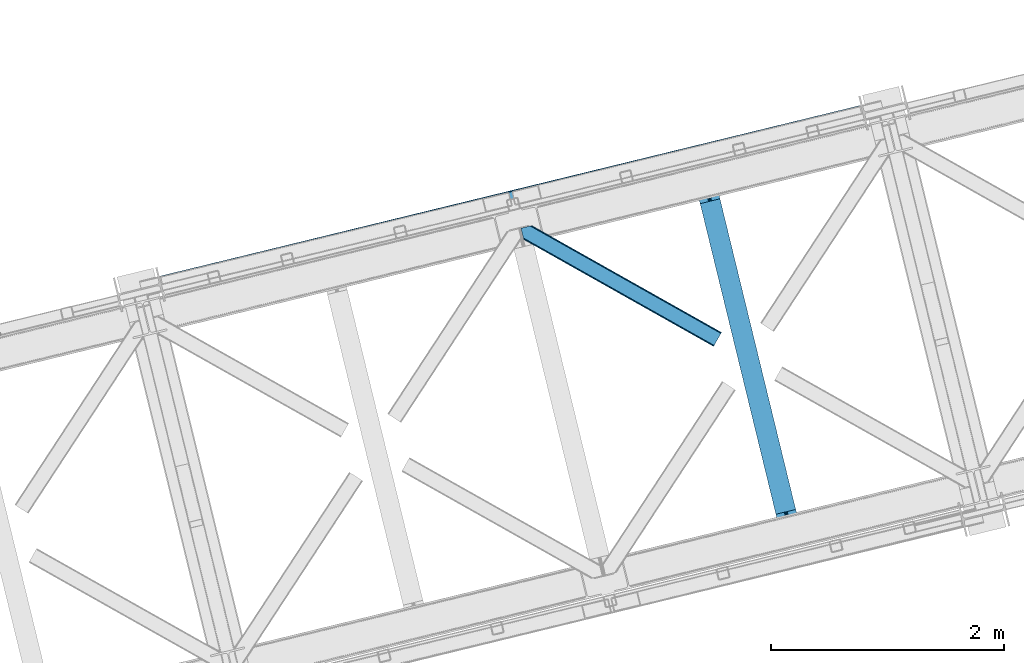
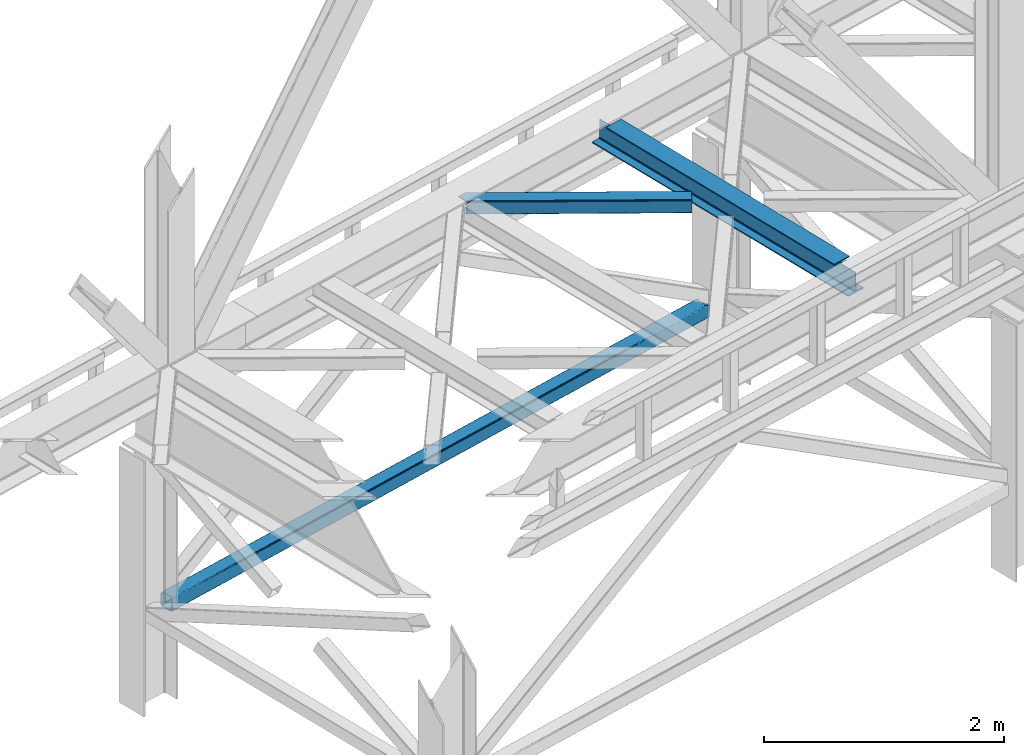
# One storey, part 49 of 92: 2 members, 1 beam.
"""IFC4 building model written with IfcOpenShell, lengths in millimetres."""

import ifcopenshell
import ifcopenshell.guid

model = None  # the IFC model being written
_history = None  # IfcOwnerHistory: only IFC2X3 demands one
_inside = {}  # id of a spatial element -> (the spatial element, [elements in it])
_under = {}  # id of a project, library or spatial element -> (it, [spatial elements below it])
_declared = {}  # id of a project -> (the project, [libraries it declares])
_typed = {}  # id of a type object -> (the type object, [elements of that type])
_made_of = {}  # id of a material, layer set ... -> (it, [elements and type objects made of it])


def new_model(schema):
    """Start an empty IFC model of exactly this schema.

    Asked for "IFC4X3", IfcOpenShell would pick the latest addendum, in which some entities
    have other attributes; the version numbers below select the first issue.
    IFC2X3 requires an IfcOwnerHistory on every rooted entity: one is made here for all.
    """
    global model, _history
    if schema == "IFC4X3":
        model = ifcopenshell.file(schema_version=(4, 3, 0, 0))
    else:
        model = ifcopenshell.file(schema=schema)
    _inside.clear()
    _under.clear()
    _declared.clear()
    _typed.clear()
    _made_of.clear()
    _history = None
    if model.schema == "IFC2X3":
        org = make("IfcOrganization", Name="unknown")
        user = make(
            "IfcPersonAndOrganization",
            ThePerson=make("IfcPerson", FamilyName="unknown"),
            TheOrganization=org,
        )
        app = make(
            "IfcApplication",
            ApplicationDeveloper=org,
            Version="unknown",
            ApplicationFullName="unknown",
            ApplicationIdentifier="unknown",
        )
        _history = make(
            "IfcOwnerHistory",
            OwningUser=user,
            OwningApplication=app,
            ChangeAction="ADDED",
            CreationDate=0,
        )
    return model


def make(cls, **values):
    """One entity of the class cls with the attributes given. An attribute that is None is left unset."""
    return model.create_entity(
        cls, **{name: value for name, value in values.items() if value is not None}
    )


def entity(cls, *values):
    """Any entity or typed value of the class cls, its attributes in the order of the schema. None: left unset."""
    e = model.create_entity(cls)
    for i, value in enumerate(values):
        if value is not None:
            e[i] = value
    return e


def rooted(cls, **values):
    """An entity with a GlobalId (a new one), such as an element, a storey or a relation."""
    return make(cls, GlobalId=ifcopenshell.guid.new(), OwnerHistory=_history, **values)


def si_unit(unit_type, name, prefix=None):
    """IfcSIUnit, for example si_unit("LENGTHUNIT", "METRE", prefix="MILLI")."""
    return make("IfcSIUnit", UnitType=unit_type, Prefix=prefix, Name=name)


def converted_unit(unit_type, name, factor, base, dimensions=None, offset=None):
    """IfcConversionBasedUnit, such as the inch: factor (a typed value) times the base unit."""
    return make(
        "IfcConversionBasedUnit"
        if offset is None
        else "IfcConversionBasedUnitWithOffset",
        ConversionOffset=offset,
        Dimensions=None
        if dimensions is None
        else entity("IfcDimensionalExponents", *dimensions),
        UnitType=unit_type,
        Name=name,
        ConversionFactor=make(
            "IfcMeasureWithUnit", ValueComponent=factor, UnitComponent=base
        ),
    )


def derived_unit(unit_type, elements):
    """IfcDerivedUnit: a product of units, each with its exponent."""
    return make(
        "IfcDerivedUnit",
        Elements=[
            make("IfcDerivedUnitElement", Unit=unit, Exponent=power)
            for unit, power in elements
        ],
        UnitType=unit_type,
    )


def assignment(units):
    """IfcUnitAssignment: the units of a project."""
    return None if units is None else make("IfcUnitAssignment", Units=units)


def point(xyz):
    """IfcCartesianPoint."""
    return None if xyz is None else make("IfcCartesianPoint", Coordinates=xyz)


def direction(xyz):
    """IfcDirection."""
    return None if xyz is None else make("IfcDirection", DirectionRatios=xyz)


def frame(location, z_axis=None, x_axis=None):
    """IfcAxis2Placement3D, a coordinate frame: its origin and axes. An axis left out is left unset."""
    return make(
        "IfcAxis2Placement3D",
        Location=point(location),
        Axis=direction(z_axis),
        RefDirection=direction(x_axis),
    )


def origin():
    """The frame at (0, 0, 0) with its axes left unset."""
    return frame((0.0, 0.0, 0.0))


def place(relative_to, where):
    """IfcLocalPlacement: puts the frame where relative to a parent placement (None: the world)."""
    return make(
        "IfcLocalPlacement", PlacementRelTo=relative_to, RelativePlacement=where
    )


def context(
    kind, dimensions, precision=None, world=None, true_north=None, identifier=None
):
    """IfcGeometricRepresentationContext, for example the 3D "Model" context."""
    return make(
        "IfcGeometricRepresentationContext",
        ContextIdentifier=identifier,
        ContextType=kind,
        CoordinateSpaceDimension=dimensions,
        Precision=precision,
        WorldCoordinateSystem=world,
        TrueNorth=true_north,
    )


def subcontext(parent, identifier, kind, view, scale=None):
    """IfcGeometricRepresentationSubContext, for example "Body" below "Model"."""
    return make(
        "IfcGeometricRepresentationSubContext",
        ContextIdentifier=identifier,
        ContextType=kind,
        ParentContext=parent,
        TargetScale=scale,
        TargetView=view,
    )


def project(units=None, contexts=None):
    """IfcProject with its units and contexts."""
    return rooted(
        "IfcProject",
        Name="project",
        RepresentationContexts=contexts,
        UnitsInContext=assignment(units),
    )


def spatial(cls, under=None, at=None, **own):
    """A site, building, storey or space (cls), placed at a placement, below another one or the project."""
    s = rooted(cls, ObjectPlacement=at, **own)
    if under is not None:
        _under.setdefault(under.id(), (under, []))[1].append(s)
    return s


def point_list(points):
    """IfcCartesianPointList2D or 3D."""
    cls = (
        "IfcCartesianPointList2D" if len(points[0]) == 2 else "IfcCartesianPointList3D"
    )
    return make(cls, CoordList=points)


def triangles(points, corners, closed=None, point_numbers=None):
    """IfcTriangulatedFaceSet: each triangle names its three corners, points numbered from 1."""
    return make(
        "IfcTriangulatedFaceSet",
        Coordinates=point_list(points),
        Closed=closed,
        CoordIndex=corners,
        PnIndex=point_numbers,
    )


def polygons(points, faces, closed=None, point_numbers=None):
    """IfcPolygonalFaceSet: a face is its outer loop, then its inner loops; points numbered from 1."""
    made = []
    for loops in faces:
        if len(loops) == 1:
            made.append(make("IfcIndexedPolygonalFace", CoordIndex=loops[0]))
        else:
            made.append(
                make(
                    "IfcIndexedPolygonalFaceWithVoids",
                    CoordIndex=loops[0],
                    InnerCoordIndices=loops[1:],
                )
            )
    return make(
        "IfcPolygonalFaceSet",
        Coordinates=point_list(points),
        Closed=closed,
        Faces=made,
        PnIndex=point_numbers,
    )


def shape(context_of_items, identifier, shape_type, items):
    """IfcShapeRepresentation: the items that make up one representation, for example the "Body"."""
    return make(
        "IfcShapeRepresentation",
        ContextOfItems=context_of_items,
        RepresentationIdentifier=identifier,
        RepresentationType=shape_type,
        Items=items,
    )


def material(Name=None, Category=None):
    """IfcMaterial."""
    return make("IfcMaterial", Name=Name, Category=Category)


def made_of(thing, what):
    """Note that an element or type object is made of a material, layer set ...; save() writes the relation."""
    if what is not None:
        _made_of.setdefault(what.id(), (what, []))[1].append(thing)
    return thing


def type_object(cls, material=None, **own):
    """A type object (cls), such as IfcWallType, which elements share."""
    return made_of(rooted(cls, **own), material)


def element(
    cls,
    number,
    at=None,
    inside=None,
    cuts=None,
    type_object=None,
    material=None,
    context=None,
    identifier="Body",
    shape_type=None,
    held_by="IfcProductDefinitionShape",
    body=None,
    shapes=None,
    **own,
):
    """One element of the class cls, such as IfcWall. Its Tag is "e" and its number.

    at: its placement. inside: the storey or other place that contains it. cuts: it is an
    opening in that element (IfcRelVoidsElement). A single representation is given by context,
    identifier, shape_type and body (its items); several are given by shapes. held_by: the class
    of the entity that holds the representations. save() writes the other relations.
    """
    e = rooted(cls, Tag="e%d" % number, ObjectPlacement=at, **own)
    if body is not None:
        shapes = [shape(context, identifier, shape_type, body)]
    if shapes is not None:
        e.Representation = make(held_by, Representations=shapes)
    if inside is not None:
        _inside.setdefault(inside.id(), (inside, []))[1].append(e)
    if cuts is not None:
        rooted(
            "IfcRelVoidsElement", RelatingBuildingElement=cuts, RelatedOpeningElement=e
        )
    if type_object is not None:
        _typed.setdefault(type_object.id(), (type_object, []))[1].append(e)
    return made_of(e, material)


def aggregate(whole, parts):
    """IfcRelAggregates: a whole, such as a stair, and the parts it consists of."""
    return rooted("IfcRelAggregates", RelatingObject=whole, RelatedObjects=parts)


def save(model, path):
    """Write the relations noted so far, then the file.

    IfcRelAggregates (storeys below a building ...), IfcRelContainedInSpatialStructure (elements
    in a storey), IfcRelDefinesByType, IfcRelAssociatesMaterial and IfcRelDeclares: one each for
    every whole, place, type object, material and project.
    """
    for whole, parts in _under.values():
        aggregate(whole, parts)
    for where, things in _inside.values():
        rooted(
            "IfcRelContainedInSpatialStructure",
            RelatedElements=things,
            RelatingStructure=where,
        )
    for kind, things in _typed.values():
        rooted("IfcRelDefinesByType", RelatedObjects=things, RelatingType=kind)
    for what, things in _made_of.values():
        rooted("IfcRelAssociatesMaterial", RelatedObjects=things, RelatingMaterial=what)
    for by, libraries in _declared.values():
        rooted("IfcRelDeclares", RelatingContext=by, RelatedDefinitions=libraries)
    model.write(path)


model = new_model("IFC4")

# Units and contexts
model_context = context("Model", 3, precision=0.01, world=origin(), true_north=direction((6.12303176911189e-17, 1.0)))
plan_context = context("Plan", 3, precision=0.01, world=origin(), true_north=direction((6.12303176911189e-17, 1.0)))
body_context = subcontext(model_context, "Body", "Model", "MODEL_VIEW")
ifc_project = project(units=[si_unit("LENGTHUNIT", "METRE", prefix="MILLI"), si_unit("AREAUNIT", "SQUARE_METRE"), si_unit("VOLUMEUNIT", "CUBIC_METRE"), converted_unit("PLANEANGLEUNIT", "DEGREE", entity("IfcRatioMeasure", 0.0174532925199433), si_unit("PLANEANGLEUNIT", "RADIAN"), dimensions=[0, 0, 0, 0, 0, 0, 0]), si_unit("MASSUNIT", "GRAM", prefix="KILO"), derived_unit("MASSDENSITYUNIT", [(si_unit("MASSUNIT", "GRAM", prefix="KILO"), 1), (si_unit("LENGTHUNIT", "METRE"), -3)]), derived_unit("MOMENTOFINERTIAUNIT", [(si_unit("LENGTHUNIT", "METRE"), 4)]), si_unit("TIMEUNIT", "SECOND"), si_unit("FREQUENCYUNIT", "HERTZ"), si_unit("THERMODYNAMICTEMPERATUREUNIT", "DEGREE_CELSIUS"), derived_unit("THERMALTRANSMITTANCEUNIT", [(si_unit("MASSUNIT", "GRAM", prefix="KILO"), 1), (si_unit("THERMODYNAMICTEMPERATUREUNIT", "KELVIN"), -1), (si_unit("TIMEUNIT", "SECOND"), -3)]), derived_unit("VOLUMETRICFLOWRATEUNIT", [(si_unit("LENGTHUNIT", "METRE"), 3), (si_unit("TIMEUNIT", "SECOND"), -1)]), derived_unit("MASSFLOWRATEUNIT", [(si_unit("MASSUNIT", "GRAM", prefix="KILO"), 1), (si_unit("TIMEUNIT", "SECOND"), -1)]), derived_unit("ROTATIONALFREQUENCYUNIT", [(si_unit("TIMEUNIT", "SECOND"), -1)]), si_unit("ELECTRICCURRENTUNIT", "AMPERE"), si_unit("ELECTRICVOLTAGEUNIT", "VOLT"), si_unit("POWERUNIT", "WATT"), si_unit("FORCEUNIT", "NEWTON", prefix="KILO"), si_unit("ILLUMINANCEUNIT", "LUX"), si_unit("LUMINOUSFLUXUNIT", "LUMEN"), si_unit("LUMINOUSINTENSITYUNIT", "CANDELA"), derived_unit("USERDEFINED", [(si_unit("MASSUNIT", "GRAM", prefix="KILO"), -1), (si_unit("LENGTHUNIT", "METRE"), -2), (si_unit("TIMEUNIT", "SECOND"), 3), (si_unit("LUMINOUSFLUXUNIT", "LUMEN"), 1)]), derived_unit("LINEARVELOCITYUNIT", [(si_unit("LENGTHUNIT", "METRE"), 1), (si_unit("TIMEUNIT", "SECOND"), -1)]), si_unit("PRESSUREUNIT", "PASCAL"), derived_unit("USERDEFINED", [(si_unit("LENGTHUNIT", "METRE"), -2), (si_unit("MASSUNIT", "GRAM", prefix="KILO"), 1), (si_unit("TIMEUNIT", "SECOND"), -2)]), derived_unit("LINEARFORCEUNIT", [(si_unit("MASSUNIT", "GRAM", prefix="KILO"), 1), (si_unit("LENGTHUNIT", "METRE"), 1), (si_unit("TIMEUNIT", "SECOND"), -2), (si_unit("LENGTHUNIT", "METRE"), -1)]), derived_unit("PLANARFORCEUNIT", [(si_unit("MASSUNIT", "GRAM", prefix="KILO"), 1), (si_unit("LENGTHUNIT", "METRE"), 1), (si_unit("TIMEUNIT", "SECOND"), -2), (si_unit("LENGTHUNIT", "METRE"), -2)])], contexts=[model_context, plan_context])

# Site, building, storey
site_placement = place(None, origin())
site = spatial("IfcSite", under=ifc_project, at=site_placement, CompositionType="ELEMENT")
building_placement = place(site_placement, origin())
building = spatial("IfcBuilding", under=site, at=building_placement, CompositionType="ELEMENT")
storey_placement = place(building_placement, frame((0.0, 0.0, 15900.0)))
storey = spatial("IfcBuildingStorey", under=building, at=storey_placement, Name="05", CompositionType="ELEMENT", Elevation=15900.0)

# Beam
ifc_material = material(Name="Metal painted (White)")
beam_type = type_object("IfcBeamType", PredefinedType="BEAM")
beam_placement = place(storey_placement, frame((-38213.17, 8471.84, 3441.0)))
element("IfcBeam", 1, at=beam_placement, inside=storey, type_object=beam_type, material=ifc_material, ObjectType="Steel Beam", PredefinedType="BEAM", context=body_context, shape_type="Tessellation", body=[
    polygons([(900.985346189436, 41.4445662733092, 11.000000000004), (900.985346189436, 41.4445662733092, 2.16573425859679e-12), (170.021610174757, 3040.13999372697, 2.16573425859679e-12), (170.021610174765, 3040.13999372697, 11.000000000004), (834.91980623581, 25.3403919499667, 11.000000000004), (103.956070221139, 3024.03581940363, 11.000000000004), (828.971056214518, 23.8903211957407, 12.2179274798217), (98.007320199847, 3022.5857486494, 12.2179274798217), (823.927949458409, 22.6610105689183, 15.6862915010235), (92.9642134437384, 3021.35643802258, 15.6862915010235), (820.558253255242, 21.8396114687119, 20.8770650821657), (89.5945172405625, 3020.53503892237, 20.8770650821657), (819.374973305547, 21.5511744621206, 27.0000000000047), (88.4112372908679, 3020.24660191578, 27.0000000000047), (81.6103728838801, 3018.58881926485, 27.0000000000047), (81.6103728838801, 3018.58881926485, 203.000000000006), (88.4112372908766, 3020.24660191578, 203.000000000006), (4.33146851719357e-12, 2998.69542745366, 2.16573425859679e-12), (4.33146851719357e-12, 2998.69542745366, 10.9999999999997), (66.0655399536129, 3014.799601777, 11.000000000004), (72.0142899749097, 3016.24967253123, 12.2179274798217), (77.0573967310183, 3017.47898315805, 15.6862915010192), (80.4270929341986, 3018.30038225826, 20.8770650821657), (819.374973305556, 21.5511744621206, 203.000000000006), (812.574108898559, 19.8933918111876, 203.000000000006), (812.574108898559, 19.8933918111876, 27.0000000000047), (811.390828948878, 19.6049548045963, 20.8770650821657), (808.021132745698, 18.7835557043887, 15.6862915010192), (802.978025989589, 17.5542450775685, 12.2179274798217), (797.029275968292, 16.1041743233403, 11.000000000004), (730.963736014684, 0.0, 10.9999999999997), (730.963736014684, 0.0, 2.16573425859679e-12), (779.675212882762, 184.415062601692, 203.069791966819), (128.020401343508, 2857.75452019162, 203.000000000006), (128.243282132658, 2856.8401777572, 203.617301946336), (128.256196377182, 2856.7871977843, 217.000003693143), (779.530009633833, 185.010597404073, 217.000003676718), (779.530880241726, 185.007025963194, 204.00000679514), (772.964911718315, 182.385463974441, 203.006342981529), (772.742064056778, 183.299815969775, 203.617301946336), (772.72914981225, 183.352795942668, 217.000003693143), (121.455336555608, 2855.1293963229, 217.000003676718), (121.45446594771, 2855.13296776377, 204.00000679514), (121.31016635866, 2855.72494066435, 203.076120467494), (121.21953693652, 2856.09673754069, 203.000000000006), (780.713494357868, 185.298194377514, 223.122939328039), (784.082490766535, 186.122464201392, 228.313710402595), (789.125126170558, 187.353708426697, 231.782072735464), (795.073705041266, 188.80448128138, 232.999999602236), (861.13915590679, 204.909021065315, 232.999999283132), (861.137682570352, 204.915065042187, 243.999994005812), (691.116301666435, 163.469558245297, 243.999994827032), (691.117775002873, 163.463514268424, 233.000000104353), (757.183225868396, 179.568054052358, 232.999999785253), (763.132130996722, 181.017488520581, 231.782072861016), (768.175695503857, 182.244921343716, 228.313710479427), (771.546082413598, 183.063487001148, 223.12293937232), (120.271851831572, 2854.84179934945, 223.122939328039), (116.902855422893, 2854.01752952557, 228.313710402595), (111.860220018873, 2852.78628530027, 231.782072735464), (105.911641148157, 2851.33551244559, 232.999999602236), (39.8461902826462, 2835.23097266165, 232.999999283128), (39.8476636190837, 2835.22492868478, 243.999994005812), (209.869044523001, 2876.67043548167, 243.999994827032), (209.867571186563, 2876.67647945855, 233.000000104357), (143.80212032104, 2860.57193967461, 232.999999785253), (137.853215192705, 2859.12250520638, 231.782072861012), (132.809650685574, 2857.89507238325, 228.313710479427), (129.439263775834, 2857.07650672582, 223.12293937232)], [[[1, 2, 3, 4]], [[5, 1, 4, 6]], [[7, 5, 6, 8]], [[9, 7, 8, 10]], [[11, 9, 10, 12]], [[13, 11, 12, 14]], [[15, 16, 17, 14, 12, 10, 8, 6, 4, 3, 18, 19, 20, 21, 22, 23]], [[13, 24, 25, 26, 27, 28, 29, 30, 31, 32, 2, 1, 5, 7, 9, 11]], [[2, 32, 18, 3]], [[32, 31, 19, 18]], [[31, 30, 20, 19]], [[27, 26, 15, 23]], [[28, 27, 23, 22]], [[29, 28, 22, 21]], [[30, 29, 21, 20]], [[33, 24, 13, 14, 17, 34, 35, 36, 37, 38]], [[25, 39, 40, 41, 42, 43, 44, 16, 15, 26]], [[39, 25, 24, 33]], [[45, 34, 17, 16]], [[41, 40, 38, 37, 46, 47, 48, 49, 50, 51, 52, 53, 54, 55, 56, 57]], [[42, 58, 59, 60, 61, 62, 63, 64, 65, 66, 67, 68, 69, 36, 35, 43]], [[46, 37, 36, 69]], [[47, 46, 69, 68]], [[48, 47, 68, 67]], [[49, 48, 67, 66]], [[50, 49, 66, 65]], [[51, 50, 65, 64]], [[52, 51, 64, 63]], [[53, 52, 63, 62]], [[54, 53, 62, 61]], [[55, 54, 61, 60]], [[56, 55, 60, 59]], [[57, 56, 59, 58]], [[41, 57, 58, 42]]], closed=False),
])

# Members
member_type_1 = type_object("IfcMemberType", PredefinedType="BRACE")
member_1_placement = place(storey_placement, frame((-42814.58, 10549.19, 828.01)))
element("IfcMember", 2, at=member_1_placement, inside=storey, type_object=member_type_1, ObjectType="Steel Vertical Brace", PredefinedType="BRACE", context=body_context, shape_type="Tessellation", body=[
    polygons([(31.1823923917484, 8.09507685196325, 17.8030399336157), (31.49787036771, 6.80086440699434, 24.5000000000053), (6043.46200614715, 1472.2807278312, 24.5000000000053), (6043.1465281712, 1473.57494027617, 17.8030399336157), (30.2839871258991, 11.7806820741885, 12.1256313292363), (6042.24812290534, 1477.2605454984, 12.1256313292363), (28.9394286278191, 17.2965800886775, 8.33210818105647), (6040.90356440726, 1482.77644351289, 8.33210818105647), (27.3534137403731, 23.8030254244704, 7.00000000000491), (6039.31754951982, 1489.28288884868, 7.00000000000491), (31.49787036771, 6.80086440699434, 115.500000000006), (1233.89069752359, 299.896837091836, 115.500000000006), (2436.28352467949, 592.992809776676, 115.500000000006), (3638.67635183538, 886.08878246152, 115.500000000006), (4841.06917899127, 1179.18475514636, 115.500000000006), (6043.46200614715, 1472.2807278312, 115.500000000006), (5.80223927825257, 112.214262715345, 7.00000000000491), (6017.7663750577, 1577.69412613955, 7.00000000000491), (33.155653018643, 4.33146851719357e-12, 122.500000000005), (32.9849557235693, 0.700266200652317, 127.470660132269), (30.3790881322204, 11.3905410333565, 127.459327979244), (31.1823923917571, 8.09507685196974, 122.196960066389), (4.21622439081527, 118.720708051138, 8.33210818105647), (2.87166589274391, 124.236606065627, 12.1256313292407), (1.97326062688594, 127.922211287852, 17.8030399336157), (1.65778265093302, 129.216423732821, 24.5000000000053), (1.65778265093302, 129.216423732821, 115.500000000006), (1.97326062688594, 127.922211287852, 122.196960066394), (2.75017783787762, 124.7349969661, 127.339177960748), (0.160838919820344, 135.357464800191, 127.327917686072), (0.0, 136.017288139811, 122.500000000005), (0.0, 136.017288139811, 17.5000000000047), (0.315477975952922, 134.723075694844, 10.8030399336108), (1.21388324180223, 131.037470472619, 5.12563132923793), (2.55844173989092, 125.521572458126, 1.33210818105806), (4.14445662732821, 119.015127122335, 2.16573425859679e-12), (29.0111963913148, 17.0021610174804, 6.49720277579036e-12), (30.5972112787521, 10.4957156816875, 1.33210818105806), (31.9417697768321, 4.97981766719851, 5.12563132923793), (32.8401750426901, 1.2942124449754, 10.8030399336108), (33.155653018643, 4.33146851719357e-12, 17.5000000000047), (6042.34390681963, 1476.86760290543, 127.45624675396), (6044.94930773645, 1466.17924255184, 127.467576960195), (6045.11978879809, 1465.47986342421, 122.500000000005), (6045.11978879809, 1465.47986342421, 17.5000000000047), (6044.80431082213, 1466.77407586918, 10.8030399336108), (6043.90590555628, 1470.45968109141, 5.12563132923793), (6042.56134705819, 1475.9755791059, 1.33210818105806), (6040.97533217076, 1482.48202444169, 6.49720277579036e-12), (6016.10859240677, 1584.49499054654, 2.16573425859679e-12), (6014.52257751934, 1591.00143588234, 1.33210818105806), (6013.17801902125, 1596.51733389683, 5.12563132923793), (6012.2796137554, 1600.20293911905, 10.8030399336108), (6011.96413577945, 1601.49715156402, 17.5000000000047), (6011.96413577944, 1601.49715156402, 122.500000000005), (6012.12476500034, 1600.83818849032, 127.324831620517), (6014.71364194229, 1590.21761586052, 127.336089968395), (6013.93739640643, 1593.40207471184, 122.196960066244), (6013.62191843038, 1594.69628715703, 115.500000000006), (6013.62191843038, 1594.69628715703, 24.5000000000053), (6013.93739640633, 1593.40207471206, 17.8030399336157), (6014.83580167219, 1589.71646948984, 12.1256313292407), (6016.18036017027, 1584.20057147535, 8.33210818105647), (6043.14652817119, 1473.57494027618, 122.196960066389), (4811.22909127449, 1301.60031447219, 115.500000000006), (3608.8362641186, 1008.50434178735, 115.500000000006), (2406.4434369627, 715.408369102503, 115.500000000006), (1204.05060980682, 422.312396417663, 115.500000000006), (3636.11791009549, 896.584498143203, 131.667891818953), (3634.53189520805, 903.090943478994, 133.000000000004), (4836.92472236394, 1196.18691616384, 133.000000000004), (4838.51073725137, 1189.68047082805, 131.667891818953), (2433.72508293959, 603.488525458363, 131.667891818953), (2432.13906805215, 609.994970794152, 133.000000000004), (1231.33225578369, 310.392552773519, 131.667891818953), (1229.74624089627, 316.89899810931, 133.000000000004), (3637.46246859357, 891.068600128712, 127.874368670769), (4839.85529574946, 1184.16457281355, 127.874368670771), (2435.06964143768, 597.972627443872, 127.874368670769), (1232.67681428178, 304.876654759035, 127.874368670766), (3638.36087385943, 887.382994906487, 122.196960066394), (4840.75370101531, 1180.47896759133, 122.196960066394), (2435.96804670353, 594.287022221647, 122.196960066394), (1233.57521954764, 301.191049536799, 122.1969600664), (31.5504186274805, 12.1281026343613, 127.832047239099), (6022.29615988911, 1481.61969697296, 132.66374240706), (6026.48857358031, 1479.26263699122, 131.667891818949), (6032.74254555655, 1477.67299982283, 130.0507182153), (6040.81773918208, 1476.91187433268, 127.874368670773), (6020.32641658999, 1484.6535992748, 133.000000000004), (45.981349439462, 24.8297337603205, 132.66374240706), (46.3340058948892, 28.4297455728429, 133.000000000004), (43.3438788514517, 20.80781722677, 131.667891818953), (38.5229506464551, 16.5185559690675, 130.0507182153), (4811.54456925045, 1300.30610202722, 122.1969600664), (3609.15174209455, 1007.21012934238, 122.196960066394), (2406.75891493867, 714.114156657536, 122.196960066394), (1204.36608778277, 421.018183972692, 122.196960066394), (3610.05014736041, 1003.52452412015, 127.874368670769), (4812.4429745163, 1296.62049680499, 127.874368670766), (2407.65732020452, 710.428551435313, 127.874368670769), (1205.26449304862, 417.332578750467, 127.874368670771), (3611.39470585849, 998.008626105662, 131.667891818953), (4813.78753301438, 1291.10459879051, 131.667891818955), (2409.00187870261, 704.912653420822, 131.667891818953), (1206.60905154672, 411.816680735978, 131.667891818953), (3612.98072074592, 991.502180769869, 133.000000000007), (4815.37354790182, 1284.59815345471, 133.000000000004), (2410.58789359003, 698.406208085027, 133.000000000007), (1208.19506643414, 405.310235400185, 133.000000000004), (23.157414935699, 119.958818466469, 132.66374240706), (18.9881108930707, 122.321511669539, 131.667891818949), (12.7554368909559, 123.916340444452, 130.0507182153), (4.69891109592004, 124.682016415775, 127.874368670769), (6013.19586234008, 1589.26654453752, 127.819904909002), (5998.78356944494, 1576.58091450779, 132.66374240706), (5998.45494622164, 1572.98676104987, 133.000000000004), (6001.39793038448, 1580.59719782003, 131.667891818953), (6006.1975606155, 1584.88126747126, 130.0507182153), (25.1031250026595, 116.919057810016, 133.000000000004), (47.3929578131527, 129.55740684651, 140.000000000009), (45.4472477462008, 132.597167502963, 139.663742407065), (41.2779437035726, 134.959860706036, 138.667891818956), (35.0452697014491, 136.554689480946, 137.050718215304), (26.9887439064132, 137.320365452269, 134.874368670774), (17.4179740866102, 137.227464121819, 132.222479077849), (6.70075955886753, 136.279555635628, 129.196960066396), (38.4511594356894, 2.83031863612196, 129.123003693295), (48.7046952331501, 6.8258830255562, 132.222479077851), (57.2599525703218, 11.1513925842091, 134.874368670769), (64.0790728249936, 15.5431646613821, 137.050718215304), (68.9000010299816, 19.8324259190867, 138.667891818953), (71.5374716179832, 23.854342452633, 139.663742407065), (71.8901280734191, 27.4543542651554, 140.000000000007), (6006.19826436872, 1598.53798671144, 129.117416141014), (5995.9325517923, 1594.5536438762, 132.222479077843), (5987.39261474748, 1590.23186880089, 134.874368670763), (5980.59216232308, 1585.84464720485, 137.050718215296), (5975.79253209206, 1581.56057755362, 138.667891818949), (5973.17817115253, 1577.54429424139, 139.663742407056), (5972.84954792923, 1573.95014078346, 140.000000000001), (5998.08585989271, 1472.02726181223, 140.000000000001), (6000.05560319183, 1468.99335951039, 139.663742407056), (6004.24801688302, 1466.63629952865, 138.667891818951), (6010.50198885927, 1465.04666236026, 137.050718215296), (6018.5771824848, 1464.28553687012, 134.874368670765), (6028.16327259719, 1464.38217268398, 132.222479077843), (6038.89187112938, 1465.33285614169, 129.196960066392), (4813.71576525089, 1291.3990178617, 140.000000000005), (3611.322938095, 998.303045176859, 140.000000000005), (2408.9301109391, 705.207072492014, 140.000000000005), (1206.53728378321, 412.111099807175, 140.000000000005), (1231.4040235472, 310.098133702318, 140.000000000003), (2433.79685070308, 603.19410638716, 140.000000000003), (3636.18967785898, 896.290079072004, 140.000000000003), (4838.58250501488, 1189.38605175685, 140.000000000005), (3640.01865651035, 880.582130499499, 129.196960066394), (3640.33413448631, 879.28791805453, 122.500000000005), (4842.7269616422, 1172.38389073937, 122.500000000005), (4842.41148366624, 1173.67810318434, 129.196960066392), (2437.62582935447, 587.486157814659, 129.196960066394), (2437.94130733042, 586.191945369686, 122.500000000005), (1235.23300219857, 294.390185129813, 129.196960066388), (1235.54848017453, 293.095972684846, 122.500000000005), (3639.1202512445, 884.267735721724, 134.874368670769), (4841.51307840039, 1177.36370840656, 134.874368670769), (2436.72742408862, 591.171763036882, 134.874368670769), (1234.33459693272, 298.075790352036, 134.874368670769), (3637.77569274641, 889.783633736213, 138.667891818953), (4840.1685199023, 1182.87960642106, 138.667891818953), (2435.38286559053, 596.687661051374, 138.667891818953), (1232.99003843464, 303.591688366527, 138.667891818953), (3609.73692320756, 1004.80949051265, 138.667891818951), (4812.12975036345, 1297.90546319749, 138.667891818953), (2407.34409605168, 711.713517827812, 138.667891818951), (1204.95126889578, 418.617545142968, 138.667891818953), (3608.39236470948, 1010.32538852714, 134.874368670769), (4810.78519186536, 1303.42136121198, 134.874368670769), (2405.99953755359, 717.229415842301, 134.874368670769), (1203.60671039769, 424.133443157459, 134.874368670769), (3607.49395944362, 1014.01099374937, 129.196960066394), (4809.88678659951, 1307.10696643421, 129.196960066388), (2405.10113228774, 720.915021064528, 129.196960066394), (1202.70830513184, 427.819048379682, 129.196960066392), (3607.17848146767, 1015.30520619434, 122.500000000005), (4809.57130862356, 1308.40117887918, 122.500000000005), (2404.78565431177, 722.209233509495, 122.500000000005), (1202.39282715588, 429.113260824653, 122.500000000005)], [[[1, 2, 3, 4]], [[5, 1, 4, 6]], [[7, 5, 6, 8]], [[9, 7, 8, 10]], [[2, 11, 12, 13, 14, 15, 16, 3]], [[17, 9, 10, 18]], [[19, 20, 21, 22, 11, 2, 1, 5, 7, 9, 17, 23, 24, 25, 26, 27, 28, 29, 30, 31, 32, 33, 34, 35, 36, 37, 38, 39, 40, 41]], [[42, 43, 44, 45, 46, 47, 48, 49, 50, 51, 52, 53, 54, 55, 56, 57, 58, 59, 60, 61, 62, 63, 18, 10, 8, 6, 4, 3, 16, 64]], [[23, 17, 18, 63]], [[24, 23, 63, 62]], [[25, 24, 62, 61]], [[26, 25, 61, 60]], [[27, 26, 60, 59, 65, 66, 67, 68]], [[69, 70, 71, 72]], [[73, 74, 70, 69]], [[75, 76, 74, 73]], [[77, 69, 72, 78]], [[79, 73, 69, 77]], [[80, 75, 73, 79]], [[81, 77, 78, 82]], [[83, 79, 77, 81]], [[84, 80, 79, 83]], [[15, 82, 64, 16]], [[14, 81, 82, 15]], [[13, 83, 81, 14]], [[12, 84, 83, 13]], [[11, 22, 84, 12]], [[84, 85, 80]], [[72, 86, 87]], [[78, 88, 89]], [[64, 89, 42]], [[89, 64, 82, 78]], [[78, 87, 88]], [[87, 78, 72]], [[72, 90, 86]], [[90, 72, 71]], [[76, 91, 92]], [[75, 91, 76]], [[91, 75, 93]], [[75, 94, 93]], [[80, 94, 75]], [[94, 80, 85]], [[85, 22, 21]], [[85, 84, 22]], [[95, 65, 59, 58]], [[96, 66, 65, 95]], [[97, 67, 66, 96]], [[98, 68, 67, 97]], [[28, 27, 68, 98]], [[99, 96, 95, 100]], [[101, 97, 96, 99]], [[102, 98, 97, 101]], [[103, 99, 100, 104]], [[105, 101, 99, 103]], [[106, 102, 101, 105]], [[107, 103, 104, 108]], [[109, 105, 103, 107]], [[110, 106, 105, 109]], [[106, 111, 112]], [[102, 113, 114]], [[28, 114, 29]], [[95, 115, 100]], [[108, 116, 117]], [[104, 116, 108]], [[116, 104, 118]], [[104, 119, 118]], [[100, 119, 104]], [[119, 100, 115]], [[115, 58, 57]], [[115, 95, 58]], [[114, 28, 98, 102]], [[102, 112, 113]], [[112, 102, 106]], [[106, 120, 111]], [[120, 106, 110]], [[92, 120, 110, 109, 107, 108, 117, 90, 71, 70, 74, 76]], [[121, 122, 123, 124, 125, 126, 127, 30, 29, 114, 113, 112, 111, 120, 92, 91, 93, 94, 85, 21, 20, 128, 129, 130, 131, 132, 133, 134]], [[135, 136, 137, 138, 139, 140, 141, 142, 143, 144, 145, 146, 147, 148, 43, 42, 89, 88, 87, 86, 90, 117, 116, 118, 119, 115, 57, 56]], [[141, 149, 150, 151, 152, 121, 134, 153, 154, 155, 156, 142]], [[157, 158, 159, 160]], [[161, 162, 158, 157]], [[163, 164, 162, 161]], [[165, 157, 160, 166]], [[167, 161, 157, 165]], [[168, 163, 161, 167]], [[169, 165, 166, 170]], [[171, 167, 165, 169]], [[172, 168, 167, 171]], [[155, 169, 170, 156]], [[154, 171, 169, 155]], [[153, 172, 171, 154]], [[172, 133, 132]], [[168, 131, 130]], [[163, 129, 128]], [[19, 128, 20]], [[44, 148, 160, 159]], [[156, 143, 142]], [[170, 143, 156]], [[143, 170, 144]], [[170, 145, 144]], [[166, 145, 170]], [[145, 166, 146]], [[166, 147, 146]], [[160, 147, 166]], [[147, 160, 148]], [[148, 44, 43]], [[164, 128, 19]], [[128, 164, 163]], [[163, 130, 129]], [[130, 163, 168]], [[168, 132, 131]], [[132, 168, 172]], [[172, 134, 133]], [[134, 172, 153]], [[173, 150, 149, 174]], [[175, 151, 150, 173]], [[176, 152, 151, 175]], [[177, 173, 174, 178]], [[179, 175, 173, 177]], [[180, 176, 175, 179]], [[181, 177, 178, 182]], [[183, 179, 177, 181]], [[184, 180, 179, 183]], [[185, 181, 182, 186]], [[187, 183, 181, 185]], [[188, 184, 183, 187]], [[31, 127, 184, 188]], [[174, 140, 139]], [[178, 138, 137]], [[182, 136, 135]], [[55, 135, 56]], [[186, 135, 55]], [[135, 186, 182]], [[182, 137, 136]], [[137, 182, 178]], [[178, 139, 138]], [[139, 178, 174]], [[174, 141, 140]], [[141, 174, 149]], [[152, 122, 121]], [[176, 122, 152]], [[122, 176, 123]], [[176, 124, 123]], [[180, 124, 176]], [[124, 180, 125]], [[180, 126, 125]], [[184, 126, 180]], [[126, 184, 127]], [[127, 31, 30]], [[19, 41, 45, 44, 159, 158, 162, 164]], [[38, 37, 49, 48]], [[39, 38, 48, 47]], [[40, 39, 47, 46]], [[41, 40, 46, 45]], [[32, 31, 188, 187, 185, 186, 55, 54]], [[33, 32, 54, 53]], [[34, 33, 53, 52]], [[35, 34, 52, 51]], [[36, 35, 51, 50]], [[37, 36, 50, 49]]], closed=True),
])
member_type_2 = type_object("IfcMemberType", PredefinedType="BRACE")
member_2_placement = place(storey_placement, frame((-39714.51, 10078.13, 3511.0)))
element("IfcMember", 3, at=member_2_placement, inside=storey, type_object=member_type_2, ObjectType="Steel Horizontal Brace", PredefinedType="BRACE", context=body_context, shape_type="Tessellation", body=[
    triangles([(1656.08961181641, 0.0, 122.500662231447), (1656.74306030274, 1.16039428710974, 129.197927856447), (23.8869140625029, 919.172964477541, 122.500662231447), (23.4590332031294, 920.944949340821, 129.197927856447), (1658.60341186524, 4.46600646972729, 134.874325561526), (22.2265502929731, 925.991152954102, 134.874325561526), (1661.38928833008, 9.41337890625073, 138.667117309571), (20.3848022460952, 933.544180297853, 138.667117309571), (1664.67513427734, 15.2479064941417, 139.999594116212), (18.2128417968779, 942.452938842775, 139.999594116212), (1656.08961181641, 0.0, 17.5000946044929), (23.8869140625029, 919.172964477541, 17.5000946044929), (1716.19757080078, 106.737670898438, 139.999594116212), (69.4469238281235, 1034.10664672852, 139.999594116212), (0.0, 1017.17861022949, 139.999594116212), (1719.4857421875, 112.573361206056, 138.667117309571), (78.971923828125, 1036.42859802246, 138.667117309571), (1722.26929321289, 117.519570922852, 134.874325561526), (87.0458496093779, 1038.39708251953, 134.874325561526), (1724.13197021485, 120.826345825197, 129.197927856447), (92.4408691406279, 1039.71328125, 129.197927856447), (1724.78541870118, 121.986740112305, 122.500662231447), (94.3337768554702, 1040.17488098145, 122.500662231447), (1724.78541870118, 121.986740112305, 17.5000946044929), (94.3337768554702, 1040.17488098145, 17.5000946044929), (1656.74306030274, 1.16039428710974, 10.8028289794929), (1658.60341186524, 4.46600646972729, 5.12526855468968), (196.053149414067, 824.820584106446, 8.8831787109375), (196.076403808598, 825.06591796875, 8.50064392089917), (23.3706665039063, 921.306555175783, 10.8691040039084), (195.062512207034, 824.998480224611, 9.50058288574292), (195.732238769531, 824.878720092775, 9.08316650390771), (23.2590454101592, 921.747225952149, 9.50058288574292), (195.220642089844, 828.57035522461, 5.12526855468968), (1664.67513427734, 15.2479064941417, 0.0), (1661.38928833008, 9.41337890625073, 1.33247680664135), (193.378894042973, 836.123382568359, 1.33247680664135), (191.206933593749, 845.032141113283, 0.0), (1716.19757080078, 106.737670898438, 0.0), (157.157849121097, 984.710824584961, 0.0), (191.346459960936, 843.222949218751, 9.20757751465135), (191.290649414063, 844.068246459961, 8.85411071777344), (191.104614257813, 845.461184692384, 8.41343994140698), (18.8686157226548, 939.774032592773, 9.50058288574292), (1724.13197021485, 120.826345825197, 10.8028289794929), (92.0548461914077, 1039.61793823242, 10.8702667236357), (150.921020507813, 1006.08742675781, 9.50058288574292), (1722.26929321289, 117.519570922852, 5.12526855468968), (153.148791503911, 1001.17261047363, 5.12526855468968), (152.293029785156, 1004.67588500977, 8.50064392089917), (151.60469970703, 1005.38165588379, 9.00061340332104), (91.5851074218735, 1039.50399169922, 9.50058288574292), (1719.4857421875, 112.573361206056, 1.33247680664135), (154.985888671879, 993.619583129883, 1.33247680664135), (156.250927734378, 986.702563476563, 9.11688537597729), (155.813745117186, 987.635064697266, 9.42384338378906), (156.692761230472, 985.760760498048, 8.80760192871094), (157.129943847656, 984.82942199707, 8.50064392089917), (155.311450195317, 988.061782836914, 9.50058288574292), (72.3118652343765, 1034.80544128418, 9.50058288574292), (159.427478027348, 975.398602294923, 6.99957275390625), (188.937304687504, 854.343200683594, 6.99957275390625), (1668.10980834961, 21.3475341796875, 6.99957275390625), (1712.76289672852, 100.639205932617, 6.99957275390625), (19.9569213867217, 935.303375244141, 12.1260040283232), (1662.04041137695, 10.5656341552749, 12.1260040283232), (1664.82396240235, 15.511843872071, 8.3320495605476), (1659.52428588867, 6.0996276855476, 24.4996673583992), (1660.177734375, 7.26002197265734, 17.8035644531265), (21.6172851562515, 928.485186767579, 24.4996673583992), (21.1894042968779, 930.257171630859, 17.8035644531265), (1716.04874267578, 106.473733520508, 8.3320495605476), (1718.83461914062, 111.421105957032, 12.1260040283232), (77.0883178710938, 1035.9704864502, 12.1260040283232), (1720.69729614258, 114.726718139649, 17.8035644531265), (82.4833374023438, 1037.28552246094, 17.8035644531265), (1721.35074462891, 115.887112426759, 24.4996673583992), (84.3808959960952, 1037.74712219238, 24.4996673583992), (1659.52428588867, 6.0996276855476, 115.501089477541), (21.6172851562515, 928.485186767579, 115.501089477541), (21.1894042968779, 930.257171630859, 122.196029663086), (19.9569213867217, 935.303375244141, 127.87475280762), (15.9432128906265, 951.765161132813, 133.000021362306), (18.1151733398438, 942.855239868164, 131.667544555665), (0.0, 1017.17861022949, 133.000021362306), (1668.10980834961, 21.3475341796875, 133.000021362306), (1664.82396240235, 15.511843872071, 131.667544555665), (1662.04041137695, 10.5656341552749, 127.87475280762), (1660.177734375, 7.26002197265734, 122.196029663086), (1718.83461914062, 111.421105957032, 127.87475280762), (1720.69729614258, 114.726718139649, 122.196029663086), (1721.35074462891, 115.887112426759, 115.501089477541), (1712.76289672852, 100.639205932617, 133.000021362306), (1716.04874267578, 106.473733520508, 131.667544555665), (77.0883178710938, 1035.9704864502, 127.87475280762), (69.0143920898481, 1034.00200195313, 131.667544555665), (82.4833374023438, 1037.28552246094, 122.196029663086), (59.4893920898467, 1031.68005065918, 133.000021362306), (84.3808959960952, 1037.74712219238, 115.501089477541)], [[1, 2, 3], [4, 3, 2], [2, 5, 4], [6, 4, 5], [5, 7, 6], [8, 6, 7], [7, 9, 8], [10, 8, 9], [11, 1, 3], [3, 12, 11], [13, 10, 9], [10, 13, 14], [15, 10, 14], [13, 16, 17], [17, 14, 13], [16, 18, 19], [19, 17, 16], [18, 20, 21], [21, 19, 18], [20, 22, 23], [23, 21, 20], [22, 24, 23], [25, 23, 24], [26, 11, 12], [27, 28, 29], [26, 30, 31], [31, 27, 26], [31, 32, 27], [30, 33, 31], [29, 34, 27], [35, 36, 37], [37, 38, 35], [36, 27, 34], [34, 37, 36], [12, 30, 26], [39, 35, 38], [38, 40, 39], [41, 42, 29], [42, 43, 29], [41, 31, 33], [33, 44, 41], [45, 46, 25], [46, 45, 47], [45, 48, 49], [49, 50, 45], [45, 50, 51], [51, 47, 45], [47, 52, 46], [48, 53, 54], [54, 49, 48], [53, 39, 40], [40, 54, 53], [25, 24, 45], [51, 55, 56], [50, 57, 55], [50, 58, 57], [47, 59, 52], [60, 52, 59], [61, 40, 62], [54, 58, 49], [58, 54, 40], [49, 58, 50], [40, 61, 58], [62, 40, 38], [37, 43, 38], [43, 37, 34], [38, 43, 62], [34, 29, 43], [63, 64, 62], [61, 62, 64], [63, 62, 43], [41, 65, 66], [41, 44, 65], [43, 66, 67], [66, 43, 42], [42, 41, 66], [43, 67, 63], [68, 69, 70], [71, 70, 69], [69, 66, 71], [65, 71, 66], [72, 58, 61], [57, 72, 55], [57, 58, 72], [56, 55, 72], [73, 74, 59], [59, 72, 73], [74, 60, 59], [73, 75, 76], [76, 74, 73], [75, 77, 78], [78, 76, 75], [61, 64, 72], [79, 68, 70], [70, 80, 79], [81, 6, 82], [80, 70, 3], [4, 81, 3], [81, 4, 6], [81, 80, 3], [70, 12, 3], [71, 65, 33], [33, 30, 71], [30, 12, 71], [70, 71, 12], [83, 10, 15], [10, 84, 8], [84, 10, 83], [15, 85, 83], [84, 82, 8], [44, 33, 65], [8, 82, 6], [86, 87, 84], [84, 83, 86], [87, 88, 82], [82, 84, 87], [88, 89, 81], [81, 82, 88], [89, 79, 80], [80, 81, 89], [20, 90, 91], [92, 24, 22], [20, 91, 22], [20, 18, 90], [91, 92, 22], [90, 18, 16], [93, 13, 9], [13, 94, 16], [94, 13, 93], [94, 90, 16], [45, 73, 48], [77, 24, 92], [24, 75, 45], [75, 24, 77], [45, 75, 73], [39, 64, 35], [53, 48, 73], [73, 72, 53], [72, 64, 39], [39, 53, 72], [88, 7, 5], [9, 86, 93], [9, 87, 86], [87, 9, 7], [88, 87, 7], [79, 1, 11], [2, 89, 88], [5, 2, 88], [89, 2, 1], [79, 89, 1], [36, 66, 27], [35, 64, 63], [63, 67, 35], [67, 66, 36], [36, 35, 67], [26, 27, 66], [11, 68, 79], [69, 11, 26], [11, 69, 68], [69, 26, 66], [95, 96, 17], [19, 95, 17], [19, 21, 97], [95, 19, 97], [97, 21, 23], [96, 14, 17], [15, 98, 85], [15, 14, 98], [96, 98, 14], [97, 23, 99], [78, 25, 76], [23, 78, 99], [25, 46, 76], [23, 25, 78], [52, 76, 46], [74, 76, 52], [60, 74, 52], [93, 83, 98], [93, 86, 83], [83, 85, 98], [77, 92, 99], [99, 78, 77], [92, 91, 99], [97, 99, 91], [91, 90, 97], [95, 97, 90], [90, 94, 95], [96, 95, 94], [94, 93, 96], [98, 96, 93]]),
])

save(model, "model.ifc")
